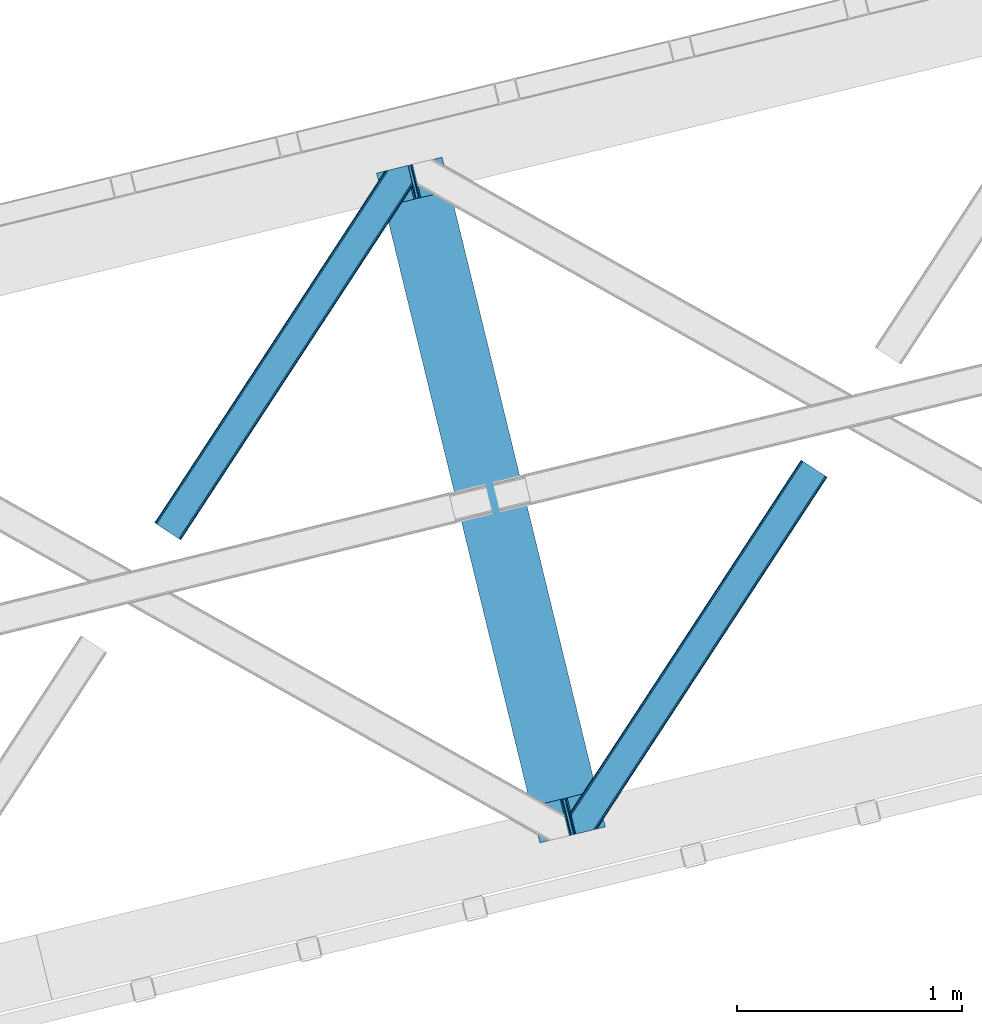
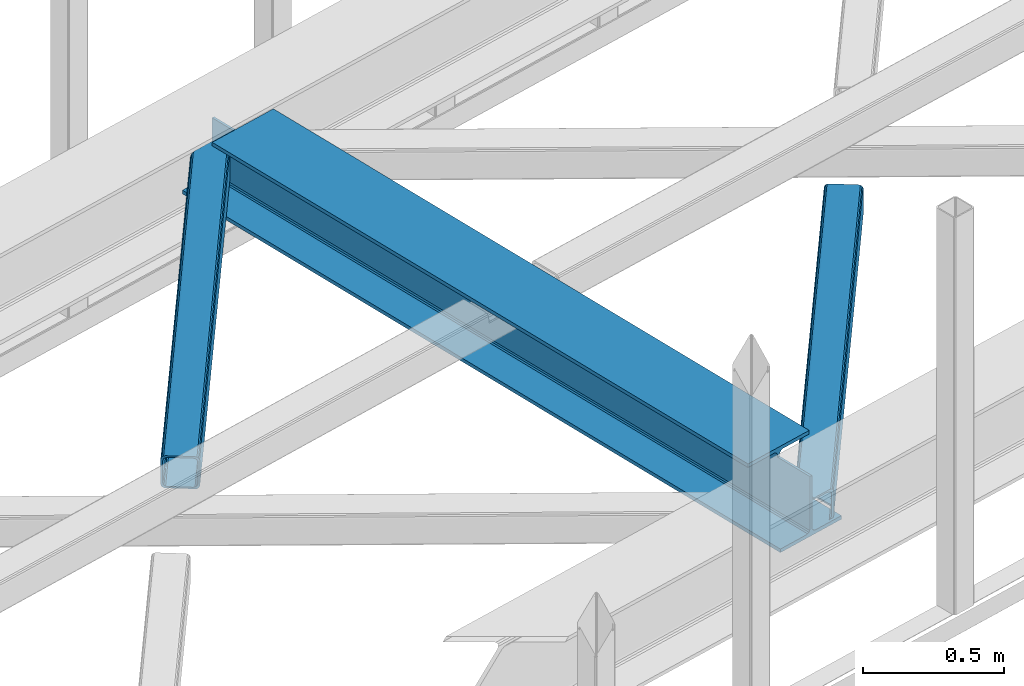
# One storey, part 31 of 66: 2 members, 1 beam.
"""IFC4 building model written with IfcOpenShell, lengths in millimetres."""

from ifc_helpers import new_model, entity, si_unit, converted_unit, derived_unit, direction, frame, origin, place, context, subcontext, project, spatial, triangles, polygons, material, type_object, element, save


model = new_model("IFC4")

# Units and contexts
model_context = context("Model", 3, precision=0.01, world=origin(), true_north=direction((6.12303176911189e-17, 1.0)))
plan_context = context("Plan", 3, precision=0.01, world=origin(), true_north=direction((6.12303176911189e-17, 1.0)))
body_context = subcontext(model_context, "Body", "Model", "MODEL_VIEW")
ifc_project = project(units=[si_unit("LENGTHUNIT", "METRE", prefix="MILLI"), si_unit("AREAUNIT", "SQUARE_METRE"), si_unit("VOLUMEUNIT", "CUBIC_METRE"), converted_unit("PLANEANGLEUNIT", "DEGREE", entity("IfcRatioMeasure", 0.0174532925199433), si_unit("PLANEANGLEUNIT", "RADIAN"), dimensions=[0, 0, 0, 0, 0, 0, 0]), si_unit("MASSUNIT", "GRAM", prefix="KILO"), derived_unit("MASSDENSITYUNIT", [(si_unit("MASSUNIT", "GRAM", prefix="KILO"), 1), (si_unit("LENGTHUNIT", "METRE"), -3)]), derived_unit("MOMENTOFINERTIAUNIT", [(si_unit("LENGTHUNIT", "METRE"), 4)]), si_unit("TIMEUNIT", "SECOND"), si_unit("FREQUENCYUNIT", "HERTZ"), si_unit("THERMODYNAMICTEMPERATUREUNIT", "DEGREE_CELSIUS"), derived_unit("THERMALTRANSMITTANCEUNIT", [(si_unit("MASSUNIT", "GRAM", prefix="KILO"), 1), (si_unit("THERMODYNAMICTEMPERATUREUNIT", "KELVIN"), -1), (si_unit("TIMEUNIT", "SECOND"), -3)]), derived_unit("VOLUMETRICFLOWRATEUNIT", [(si_unit("LENGTHUNIT", "METRE"), 3), (si_unit("TIMEUNIT", "SECOND"), -1)]), derived_unit("MASSFLOWRATEUNIT", [(si_unit("MASSUNIT", "GRAM", prefix="KILO"), 1), (si_unit("TIMEUNIT", "SECOND"), -1)]), derived_unit("ROTATIONALFREQUENCYUNIT", [(si_unit("TIMEUNIT", "SECOND"), -1)]), si_unit("ELECTRICCURRENTUNIT", "AMPERE"), si_unit("ELECTRICVOLTAGEUNIT", "VOLT"), si_unit("POWERUNIT", "WATT"), si_unit("FORCEUNIT", "NEWTON", prefix="KILO"), si_unit("ILLUMINANCEUNIT", "LUX"), si_unit("LUMINOUSFLUXUNIT", "LUMEN"), si_unit("LUMINOUSINTENSITYUNIT", "CANDELA"), derived_unit("USERDEFINED", [(si_unit("MASSUNIT", "GRAM", prefix="KILO"), -1), (si_unit("LENGTHUNIT", "METRE"), -2), (si_unit("TIMEUNIT", "SECOND"), 3), (si_unit("LUMINOUSFLUXUNIT", "LUMEN"), 1)]), derived_unit("LINEARVELOCITYUNIT", [(si_unit("LENGTHUNIT", "METRE"), 1), (si_unit("TIMEUNIT", "SECOND"), -1)]), si_unit("PRESSUREUNIT", "PASCAL"), derived_unit("USERDEFINED", [(si_unit("LENGTHUNIT", "METRE"), -2), (si_unit("MASSUNIT", "GRAM", prefix="KILO"), 1), (si_unit("TIMEUNIT", "SECOND"), -2)]), derived_unit("LINEARFORCEUNIT", [(si_unit("MASSUNIT", "GRAM", prefix="KILO"), 1), (si_unit("LENGTHUNIT", "METRE"), 1), (si_unit("TIMEUNIT", "SECOND"), -2), (si_unit("LENGTHUNIT", "METRE"), -1)]), derived_unit("PLANARFORCEUNIT", [(si_unit("MASSUNIT", "GRAM", prefix="KILO"), 1), (si_unit("LENGTHUNIT", "METRE"), 1), (si_unit("TIMEUNIT", "SECOND"), -2), (si_unit("LENGTHUNIT", "METRE"), -2)])], contexts=[model_context, plan_context])

# Site, building, storey
site_placement = place(None, origin())
site = spatial("IfcSite", under=ifc_project, at=site_placement, CompositionType="ELEMENT")
building_placement = place(site_placement, origin())
building = spatial("IfcBuilding", under=site, at=building_placement, CompositionType="ELEMENT")
storey_placement = place(building_placement, frame((0.0, 0.0, 19800.0)))
storey = spatial("IfcBuildingStorey", under=building, at=storey_placement, Name="06", CompositionType="ELEMENT", Elevation=19800.0)

# Beam
ifc_material = material(Name="Metal painted (White)")
beam_type = type_object("IfcBeamType", PredefinedType="BEAM")
beam_placement = place(storey_placement, frame((-39874.82, 8075.02, 3807.02)))
element("IfcBeam", 1, at=beam_placement, inside=storey, type_object=beam_type, material=ifc_material, ObjectType="Steel Beam", PredefinedType="BEAM", context=body_context, shape_type="Tessellation", body=[
    polygons([(1018.16648378329, 71.0478278971021, 15.5000000000008), (1018.16648378329, 71.0478278971021, 0.0), (291.465617442446, 3052.25531830421, 0.0), (291.465617442446, 3052.25531830421, 15.5000000000008), (894.779372399329, 40.9709140873291, 15.5000000000008), (168.078506058474, 3022.17840449444, 15.5000000000008), (888.087028625371, 39.3395844888243, 16.8701684147984), (161.386162284528, 3020.54707489593, 16.8701684147984), (882.413533524751, 37.9566100336508, 20.7720779386434), (155.712667183895, 3019.16410044076, 20.7720779386434), (878.622625296176, 37.0325360459151, 26.6116982174294), (151.921758955329, 3018.24002645303, 26.6116982174294), (877.291435352788, 36.7080444135018, 33.500000000001), (150.590569011932, 3017.91553482061, 33.500000000001), (140.875048430514, 3015.54727389071, 33.500000000001), (140.875048430514, 3015.54727389071, 259.000000000002), (150.590569011932, 3017.91553482061, 259.000000000002), (8.66293703438714e-12, 2981.20749040711, 0.0), (8.66293703438714e-12, 2981.20749040711, 15.4999999999965), (123.387111383972, 3011.28440421689, 15.5000000000008), (130.079455157926, 3012.91573381539, 16.8701684147984), (135.752950258551, 3014.29870827056, 20.7720779386434), (139.543858487117, 3015.22278225829, 26.6116982174294), (877.291435352783, 36.7080444135018, 259.000000000002), (867.575914771365, 34.3397834835981, 259.000000000002), (867.575914771365, 34.339783483597, 33.500000000001), (866.244724827968, 34.0152918511827, 26.6116982174294), (862.453816599397, 33.0912178634492, 20.7720779386434), (856.780321498782, 31.7082434082767, 16.8701684147984), (850.087977724828, 30.0769138097719, 15.5000000000008), (726.700866340855, 0.0, 15.4999999999965), (726.700866340855, 0.0, 0.0), (838.124523615921, 197.385937999179, 259.069791973884), (186.469722099971, 2870.72539801218, 259.000000000002), (186.69311520182, 2869.80895360721, 259.617303331124), (186.705504045446, 2869.75812937344, 266.500003008253), (837.979344808156, 197.981416001702, 266.500002998871), (837.979694928899, 197.979979696968, 260.000004007589), (828.499586345876, 194.64586594443, 259.006343171919), (828.276216326111, 195.56231748191, 259.617303331124), (828.263827482486, 195.613141715684, 266.500003008253), (176.989986719784, 2867.38985508742, 266.500002998871), (176.989636599032, 2867.39129139215, 260.000004007589), (176.844830940696, 2867.98534020594, 259.07612046749), (176.754201518561, 2868.35713708228, 259.000000000002), (839.310832678066, 198.304685446387, 273.388305639783), (843.10110926677, 199.231350618301, 279.227924098781), (848.774180214309, 200.616065081978, 283.129832400615), (855.466371895434, 202.248018612792, 284.500000377228), (978.853400583269, 232.3252716679, 284.500000138971), (978.851730776613, 232.332121736634, 299.999995328161), (687.386308679356, 161.283492472592, 299.999995890962), (687.387978486008, 161.27664240386, 284.500000701776), (810.775007173852, 191.353895458971, 284.500000463519), (817.467494069982, 192.984637925549, 283.129832461069), (823.141405718751, 194.365903570074, 279.227924137322), (826.932940505742, 195.28740721937, 273.388305663684), (175.658498849857, 2867.06658564273, 273.388305639788), (171.868222261161, 2866.13992047082, 279.227924098781), (166.195151313631, 2864.75520600714, 283.129832400619), (159.502959632506, 2863.12325247633, 284.500000377228), (36.115930944662, 2833.04599942122, 284.500000138971), (36.1176007513137, 2833.03914935249, 299.999995328161), (327.583022848575, 2904.08777861653, 299.999995890962), (327.581353041924, 2904.09462868526, 284.500000701776), (204.19432435408, 2874.01737563015, 284.500000463519), (197.501837457932, 2872.38663316357, 283.129832461065), (191.827925809181, 2871.00536751905, 279.227924137322), (188.03639102218, 2870.08386386975, 273.388305663684)], [[[1, 2, 3, 4]], [[5, 1, 4, 6]], [[7, 5, 6, 8]], [[9, 7, 8, 10]], [[11, 9, 10, 12]], [[13, 11, 12, 14]], [[15, 16, 17, 14, 12, 10, 8, 6, 4, 3, 18, 19, 20, 21, 22, 23]], [[13, 24, 25, 26, 27, 28, 29, 30, 31, 32, 2, 1, 5, 7, 9, 11]], [[2, 32, 18, 3]], [[32, 31, 19, 18]], [[31, 30, 20, 19]], [[27, 26, 15, 23]], [[28, 27, 23, 22]], [[29, 28, 22, 21]], [[30, 29, 21, 20]], [[33, 24, 13, 14, 17, 34, 35, 36, 37, 38]], [[25, 39, 40, 41, 42, 43, 44, 16, 15, 26]], [[39, 25, 24, 33]], [[45, 34, 17, 16]], [[41, 40, 38, 37, 46, 47, 48, 49, 50, 51, 52, 53, 54, 55, 56, 57]], [[42, 58, 59, 60, 61, 62, 63, 64, 65, 66, 67, 68, 69, 36, 35, 43]], [[46, 37, 36, 69]], [[47, 46, 69, 68]], [[48, 47, 68, 67]], [[49, 48, 67, 66]], [[50, 49, 66, 65]], [[51, 50, 65, 64]], [[52, 51, 64, 63]], [[53, 52, 63, 62]], [[54, 53, 62, 61]], [[55, 54, 61, 60]], [[56, 55, 60, 59]], [[57, 56, 59, 58]], [[41, 57, 58, 42]]], closed=False),
])

# Members
member_type_1 = type_object("IfcMemberType", PredefinedType="BRACE")
member_1_placement = place(storey_placement, frame((-40863.02, 9423.03, 3824.0)))
element("IfcMember", 2, at=member_1_placement, inside=storey, type_object=member_type_1, ObjectType="Steel Horizontal Brace", PredefinedType="BRACE", context=body_context, shape_type="Tessellation", body=[
    triangles([(994.776489257813, 1564.02720794678, 0.0), (1028.82557373047, 1424.34736175537, 0.0), (14.6409667968765, 67.1040435791001, 0.0), (102.486767578128, 9.58604278564417, 0.0), (1.1162109375, 75.9604797363281, 10.8039916992202), (0.0, 76.6900863647461, 17.5012573242202), (1025.02580566407, 1642.17825164795, 17.5012573242202), (4.28811035156104, 73.8821182250977, 5.12526855468968), (990.47907714844, 1585.87703704834, 9.49942016601563), (990.041894531249, 1584.44689178467, 8.74132690429906), (989.90701904297, 1583.99226837158, 8.49948120117188), (990.762780761717, 1580.48783111572, 5.12526855468968), (1027.30938720703, 1642.73519439697, 10.8691040039084), (1027.77912597657, 1642.8503036499, 9.49942016601563), (992.604528808595, 1572.9359664917, 1.33247680664135), (9.03665771484521, 70.7724243164048, 1.33247680664135), (1025.02580566407, 1642.17825164795, 122.499499511719), (0.0, 76.6900863647461, 122.499499511719), (1026.92336425781, 1642.64101409912, 129.196765136719), (1.1162109375, 75.9604797363281, 129.196765136719), (1032.31838378906, 1643.95605010986, 134.87548828125), (4.28811035156104, 73.8821182250977, 134.87548828125), (1040.39230957031, 1645.92453460693, 138.668280029298), (9.03665771484521, 70.7724243164048, 138.668280029298), (1049.91730957032, 1648.24648590088, 140.00075683594), (14.6409667968765, 67.1040435791001, 140.00075683594), (994.874157714847, 1567.85139312744, 9.49942016601563), (994.762536621092, 1567.00725860596, 9.2947814941399), (994.650915527345, 1566.15033416748, 9.08781738281323), (994.539294433598, 1565.30619964599, 8.8831787109375), (994.748583984379, 1564.14464263916, 8.49948120117188), (1047.05701904297, 1647.54769134521, 9.49942016601563), (14.892114257811, 66.9377746582031, 8.3320495605476), (20.4964233398423, 63.2693939208984, 6.99957275390625), (997.046118164064, 1554.71498565674, 6.99957275390625), (10.1435668945342, 70.0474685668942, 12.1248413085959), (1042.27591552735, 1646.3826461792, 12.1248413085959), (1036.8808959961, 1645.06761016846, 17.8035644531265), (1034.98333740234, 1644.60601043701, 24.5008300781265), (6.97166748047312, 72.1258300781246, 17.8035644531265), (5.85545654297312, 72.8560180664063, 24.5008300781265), (1026.55129394531, 1433.65958404541, 6.99957275390625), (96.6313110351548, 13.4206924438477, 6.99957275390625), (1028.71860351563, 1424.77640533447, 8.41343994140698), (1032.83463134766, 1407.88673858643, 5.12526855468968), (1033.6903930664, 1404.38230133057, 8.49948120117188), (1030.99288330078, 1415.43860321045, 1.33247680664135), (1034.98333740234, 1644.60601043701, 115.499926757813), (5.85545654297312, 72.8560180664063, 115.499926757813), (1050.3498413086, 1648.35113067627, 131.668707275392), (1059.87484130859, 1650.67308197021, 133.001184082033), (20.4964233398423, 63.2693939208984, 133.001184082033), (14.892114257811, 66.9377746582031, 131.668707275392), (1042.27591552735, 1646.3826461792, 127.873590087893), (10.1435668945342, 70.0474685668942, 127.873590087893), (1036.8808959961, 1645.06761016846, 122.197192382813), (6.97166748047312, 72.1258300781246, 122.197192382813), (1128.10788574219, 1667.30578765869, 140.00075683594), (1128.10788574219, 1667.30578765869, 133.001184082033), (1144.33015136719, 1600.75868682861, 140.00075683594), (102.486767578128, 9.58604278564417, 140.00075683594), (1142.06052246094, 1610.06974639893, 133.001184082033), (96.6313110351548, 13.4206924438477, 133.001184082033), (1146.50211181641, 1591.84876556396, 138.668280029298), (108.091076660159, 5.91766204833948, 138.668280029298), (1148.34385986329, 1584.29690093994, 134.87548828125), (112.839624023436, 2.80738677978479, 134.87548828125), (1149.57169189453, 1579.25069732666, 129.196765136719), (116.011523437504, 0.729606628417969, 129.196765136719), (1150.00422363282, 1577.47871246338, 122.499499511719), (117.127734375004, 0.0, 122.499499511719), (1150.00422363282, 1577.47871246338, 17.5012573242202), (117.127734375004, 0.0, 17.5012573242202), (106.98416748047, 6.64203643798828, 127.873590087893), (110.156066894531, 4.56367492675781, 122.197192382813), (111.272277832031, 3.83464965820167, 115.499926757813), (102.230969238284, 9.75173034667932, 131.668707275392), (116.011523437504, 0.729606628417969, 10.8039916992202), (106.98416748047, 6.64203643798828, 12.1248413085959), (112.839624023436, 2.80738677978479, 5.12526855468968), (111.272277832031, 3.83464965820167, 24.5008300781265), (110.156066894531, 4.56367492675781, 17.8035644531265), (108.091076660159, 5.91766204833948, 1.33247680664135), (102.230969238284, 9.75173034667932, 8.3320495605476), (1147.30206298828, 1588.56175689697, 122.197192382813), (1147.73459472656, 1586.78977203369, 115.499926757813), (1146.07423095703, 1593.60912322998, 127.873590087893), (1144.23248291016, 1601.160987854, 131.668707275392), (1147.73459472656, 1586.78977203369, 24.5008300781265), (1147.21369628907, 1588.92452545166, 17.8686767578147), (1149.994921875, 1577.51591949463, 16.5013183593765), (1147.10672607422, 1589.36519622803, 16.5013183593765), (1145.27427978516, 1573.10804901123, 10.8714294433594), (1034.62056884765, 1404.78809051514, 9.49942016601563), (1144.12551269531, 1572.03369598389, 9.49942016601563), (1142.79071044922, 1588.5978012085, 12.1248413085959), (1030.22548828125, 1422.81373443603, 9.49942016601563), (1029.19764404297, 1423.67182159424, 8.80643920898365), (1139.7304321289, 1590.06050262451, 9.49942016601563)], [[1, 2, 3], [4, 3, 2], [5, 6, 7], [8, 9, 10], [11, 12, 8], [5, 13, 9], [9, 8, 5], [13, 14, 9], [15, 1, 16], [3, 16, 1], [12, 15, 8], [16, 8, 15], [7, 13, 5], [17, 7, 6], [6, 18, 17], [19, 17, 20], [18, 20, 17], [21, 19, 22], [20, 22, 19], [23, 21, 24], [22, 24, 21], [25, 23, 26], [24, 26, 23], [27, 28, 9], [28, 29, 10], [29, 30, 10], [30, 31, 11], [14, 32, 27], [27, 9, 14], [33, 34, 35], [36, 33, 31], [31, 30, 36], [28, 36, 29], [28, 27, 36], [36, 30, 29], [32, 37, 27], [36, 27, 37], [35, 31, 33], [38, 39, 40], [41, 40, 39], [37, 38, 36], [40, 36, 38], [42, 35, 34], [34, 43, 42], [1, 35, 42], [31, 12, 11], [1, 31, 35], [31, 15, 12], [31, 1, 15], [2, 1, 42], [44, 2, 42], [45, 44, 46], [44, 47, 2], [44, 45, 47], [39, 48, 49], [49, 41, 39], [50, 51, 52], [52, 53, 50], [54, 50, 53], [53, 55, 54], [56, 54, 55], [55, 57, 56], [48, 56, 57], [57, 49, 48], [56, 17, 19], [50, 23, 25], [58, 51, 25], [51, 58, 59], [51, 50, 25], [54, 23, 50], [54, 56, 21], [21, 23, 54], [19, 21, 56], [39, 7, 17], [37, 14, 38], [56, 48, 17], [37, 32, 14], [39, 38, 7], [48, 39, 17], [13, 7, 38], [38, 14, 13], [60, 25, 61], [25, 60, 58], [26, 61, 25], [51, 62, 63], [51, 59, 62], [63, 52, 51], [64, 60, 61], [61, 65, 64], [66, 64, 65], [65, 67, 66], [68, 66, 67], [67, 69, 68], [70, 68, 69], [69, 71, 70], [72, 70, 71], [71, 73, 72], [69, 74, 75], [76, 73, 71], [69, 75, 71], [69, 67, 74], [75, 76, 71], [74, 67, 65], [63, 61, 26], [61, 77, 65], [77, 61, 63], [77, 74, 65], [78, 79, 80], [81, 73, 76], [73, 82, 78], [82, 73, 81], [78, 82, 79], [4, 43, 3], [83, 80, 79], [79, 84, 83], [84, 43, 4], [4, 83, 84], [55, 24, 22], [26, 52, 63], [26, 53, 52], [53, 26, 24], [55, 53, 24], [49, 18, 6], [20, 57, 55], [22, 20, 55], [57, 20, 18], [49, 57, 18], [16, 36, 8], [3, 43, 34], [34, 33, 3], [33, 36, 16], [16, 3, 33], [5, 8, 36], [6, 41, 49], [40, 6, 5], [6, 40, 41], [40, 5, 36], [85, 86, 75], [76, 75, 86], [87, 85, 74], [75, 74, 85], [88, 87, 77], [74, 77, 87], [62, 88, 63], [77, 63, 88], [86, 89, 81], [81, 76, 86], [90, 91, 92], [70, 72, 89], [72, 90, 89], [89, 86, 70], [72, 91, 90], [85, 70, 86], [68, 70, 85], [66, 85, 87], [85, 66, 68], [87, 64, 66], [88, 64, 87], [88, 62, 60], [88, 60, 64], [62, 58, 60], [62, 59, 58], [73, 78, 93], [93, 72, 73], [94, 93, 78], [94, 95, 93], [80, 45, 46], [46, 78, 80], [46, 94, 78], [47, 45, 83], [80, 83, 45], [2, 47, 4], [83, 4, 47], [93, 91, 72], [82, 81, 89], [82, 92, 96], [82, 90, 92], [84, 97, 98], [79, 96, 97], [97, 84, 79], [96, 99, 97], [43, 84, 44], [44, 42, 43], [96, 79, 82], [89, 90, 82], [96, 91, 93], [96, 92, 91], [96, 95, 99], [93, 95, 96], [99, 95, 97], [94, 97, 95]]),
])
member_type_2 = type_object("IfcMemberType", PredefinedType="BRACE")
member_2_placement = place(storey_placement, frame((-39011.7, 8114.1, 3824.0)))
element("IfcMember", 3, at=member_2_placement, inside=storey, type_object=member_type_2, ObjectType="Steel Horizontal Brace", PredefinedType="BRACE", context=body_context, shape_type="Tessellation", body=[
    triangles([(109.770043945311, 259.950411987305, 7.52047119140843), (115.030187988283, 238.366264343263, 7.77626953125218), (114.216284179689, 239.946981811524, 8.3320495605476), (108.809637451173, 259.66263885498, 8.52041015625218), (113.637249755855, 239.860359191895, 8.52041015625218), (112.209429931638, 237.677934265136, 8.52041015625218), (91.0363037109346, 232.516621398926, 8.52041015625218), (109.537499999999, 237.026811218261, 9.49942016601563), (90.2619323730469, 232.328260803223, 9.49942016601563), (5.02062377929542, 77.405158996582, 9.49942016601563), (0.62786865234375, 95.4313842773436, 9.49942016601563), (1046.62448730469, 1651.75382995606, 6.99957275390625), (1041.02017822266, 1655.42221069336, 8.3320495605476), (116.702178955078, 231.514938354493, 6.99957275390625), (1036.27395629883, 1658.53248596192, 12.1248413085959), (3.93231811523583, 81.8758163452158, 12.1248413085959), (1033.09740600586, 1660.61026611328, 17.8035644531265), (2.70216064452688, 86.922019958497, 17.8035644531265), (1031.98352050781, 1661.34045410156, 24.5008300781265), (2.26962890625146, 88.6940048217775, 24.5008300781265), (1122.75704956055, 1601.905128479, 6.99957275390625), (146.20968017578, 110.459536743164, 6.99957275390625), (1031.98352050781, 1661.34045410156, 115.499926757813), (2.26962890625146, 88.6940048217775, 115.499926757813), (1033.09740600586, 1660.61026611328, 122.197192382813), (2.70216064452688, 86.922019958497, 122.197192382813), (1036.27395629883, 1658.53248596192, 127.873590087893), (3.93231811523583, 81.8758163452158, 127.873590087893), (1041.02017822266, 1655.42221069336, 131.668707275392), (5.77174072265188, 74.3233703613287, 131.668707275392), (1046.62448730469, 1651.75382995606, 133.001184082033), (7.94370117187646, 65.4146118164063, 133.001184082033), (1027.24194946289, 1664.44491577149, 10.8039916992202), (0.518572998043965, 95.8720550537118, 10.8691040039084), (0.0, 98.0062271118159, 17.5012573242202), (1035.16472167968, 1659.25686035156, 1.33247680664135), (112.260589599609, 249.735919189453, 1.33247680664135), (110.544415283199, 256.772117614747, 5.59500732422021), (109.077062988283, 259.839953613281, 8.32042236328198), (1030.41384887695, 1662.36713562012, 5.12526855468968), (1040.76670532226, 1655.58847961426, 0.0), (114.430224609372, 240.827160644531, 0.0), (1026.12806396484, 1665.17510375977, 17.5012573242202), (1128.61250610351, 1598.0704788208, 0.0), (148.479309082031, 101.147895812989, 0.0), (150.651269531249, 92.2391372680659, 1.33247680664135), (148.509539794919, 101.029879760742, 8.49948120117188), (152.493017578126, 84.6866912841806, 5.12526855468968), (153.346453857419, 81.1828353881838, 8.49948120117188), (1026.12806396484, 1665.17510375977, 122.499499511719), (0.0, 98.0062271118159, 122.499499511719), (1040.76670532226, 1655.58847961426, 140.00075683594), (1035.16472167968, 1659.25686035156, 138.668280029298), (3.50211181640771, 83.6350112915034, 138.668280029298), (5.674072265625, 74.7262527465818, 140.00075683594), (1030.41384887695, 1662.36713562012, 134.87548828125), (1.66036376952979, 91.1874572753904, 134.87548828125), (1027.24194946289, 1664.44491577149, 129.196765136719), (0.430206298828125, 96.2342422485353, 129.196765136719), (23.8892395019502, 0.0, 140.00075683594), (23.8892395019502, 0.0, 133.001184082033), (1128.61250610351, 1598.0704788208, 140.00075683594), (93.3361633300738, 16.9286178588873, 140.00075683594), (1122.75704956055, 1601.905128479, 133.001184082033), (83.3809570312515, 14.5020217895508, 133.001184082033), (1143.25347290039, 1588.48443603516, 122.499499511719), (1142.13958740234, 1589.21404266358, 129.196765136719), (118.225341796875, 22.9956893920898, 122.499499511719), (116.332434082033, 22.5340896606449, 129.196765136719), (1138.96536254883, 1591.29182281494, 134.87548828125), (110.935089111328, 21.2184722900392, 134.87548828125), (1134.21681518554, 1594.40267944336, 138.668280029298), (102.861163330075, 19.2499877929686, 138.668280029298), (1143.25347290039, 1588.48443603516, 17.5012573242202), (118.225341796875, 22.9956893920898, 17.5012573242202), (1142.13958740234, 1589.21404266358, 10.8039916992202), (1133.10990600586, 1595.12647247315, 12.1248413085959), (1136.28180541992, 1593.04811096192, 17.8035644531265), (1137.39801635742, 1592.31908569336, 24.5008300781265), (1138.96536254883, 1591.29182281494, 5.12526855468968), (1134.21681518554, 1594.40267944336, 1.33247680664135), (1128.35903320312, 1598.2367477417, 8.3320495605476), (1133.10990600586, 1595.12647247315, 127.873590087893), (1137.39801635742, 1592.31908569336, 115.499926757813), (1136.28180541992, 1593.04811096192, 122.197192382813), (1128.35903320312, 1598.2367477417, 131.668707275392), (92.9059570312456, 16.8239730834966, 131.668707275392), (100.979882812499, 18.7918762207037, 127.873590087893), (106.374902343749, 20.1069122314457, 122.197192382813), (108.270135498045, 20.5685119628906, 115.499926757813), (108.270135498045, 20.5685119628906, 24.5008300781265), (100.979882812499, 18.7918762207037, 12.1248413085959), (115.474346923824, 22.3248001098636, 9.49942016601563), (106.374902343749, 20.1069122314457, 17.8035644531265), (96.2011047363267, 17.6268310546875, 9.49942016601563), (115.944085693358, 22.4393280029299, 10.8691040039084), (153.060424804688, 80.2398696899409, 8.99945068359375), (152.776721191403, 79.2974853515634, 9.49942016601563), (148.711853027344, 99.8683227539068, 8.8831787109375), (148.602557373044, 99.023606872558, 9.08781738281323), (148.493261718751, 98.1678451538091, 9.2947814941399), (148.381640624997, 97.3231292724604, 9.49942016601563)], [[1, 2, 3], [4, 5, 6], [6, 7, 4], [7, 6, 8], [8, 9, 7], [9, 8, 10], [10, 11, 9], [12, 13, 3], [3, 2, 12], [2, 14, 12], [15, 16, 8], [8, 13, 15], [8, 5, 13], [16, 10, 8], [8, 6, 5], [15, 17, 18], [18, 16, 15], [17, 19, 20], [20, 18, 17], [21, 12, 14], [14, 22, 21], [19, 23, 24], [24, 20, 19], [23, 25, 24], [26, 24, 25], [25, 27, 26], [28, 26, 27], [27, 29, 28], [30, 28, 29], [29, 31, 30], [32, 30, 31], [33, 34, 35], [36, 37, 38], [33, 4, 9], [33, 1, 39], [9, 34, 33], [9, 11, 34], [4, 7, 9], [40, 38, 1], [1, 33, 40], [38, 40, 36], [36, 41, 37], [42, 37, 41], [35, 43, 33], [41, 44, 42], [45, 42, 44], [14, 42, 22], [37, 2, 38], [2, 37, 42], [38, 2, 1], [42, 14, 2], [22, 42, 45], [46, 47, 45], [47, 46, 48], [45, 47, 22], [48, 49, 47], [50, 43, 35], [35, 51, 50], [52, 53, 54], [54, 55, 52], [53, 56, 57], [57, 54, 53], [56, 58, 59], [59, 57, 56], [58, 50, 51], [51, 59, 58], [28, 57, 26], [30, 32, 55], [32, 60, 55], [32, 61, 60], [54, 30, 55], [28, 54, 57], [16, 11, 10], [28, 30, 54], [51, 35, 20], [24, 26, 51], [24, 51, 20], [57, 59, 26], [26, 59, 51], [35, 18, 20], [18, 11, 16], [11, 18, 34], [35, 34, 18], [62, 55, 63], [62, 52, 55], [55, 60, 63], [64, 32, 31], [32, 64, 65], [61, 32, 65], [66, 67, 68], [69, 68, 67], [67, 70, 69], [71, 69, 70], [70, 72, 71], [73, 71, 72], [72, 62, 73], [63, 73, 62], [74, 66, 68], [68, 75, 74], [76, 77, 78], [79, 66, 74], [76, 78, 74], [76, 80, 77], [78, 79, 74], [77, 80, 81], [21, 44, 41], [44, 82, 81], [82, 44, 21], [82, 77, 81], [67, 83, 70], [84, 66, 79], [66, 85, 67], [85, 66, 84], [67, 85, 83], [62, 64, 52], [72, 70, 83], [83, 86, 72], [86, 64, 62], [62, 72, 86], [15, 36, 40], [41, 12, 21], [41, 13, 12], [13, 41, 36], [15, 13, 36], [19, 43, 50], [33, 17, 15], [40, 33, 15], [17, 33, 43], [19, 17, 43], [53, 27, 56], [52, 64, 31], [31, 29, 52], [29, 27, 53], [53, 52, 29], [58, 56, 27], [50, 23, 19], [25, 50, 58], [50, 25, 23], [25, 58, 27], [64, 86, 87], [87, 65, 64], [86, 83, 88], [88, 87, 86], [83, 85, 89], [89, 88, 83], [85, 84, 90], [90, 89, 85], [84, 79, 91], [91, 90, 84], [89, 68, 69], [87, 73, 63], [60, 65, 63], [65, 60, 61], [65, 87, 63], [88, 73, 87], [88, 89, 71], [71, 73, 88], [69, 71, 89], [91, 75, 68], [92, 93, 94], [89, 90, 68], [92, 95, 93], [91, 94, 75], [90, 91, 68], [96, 75, 94], [94, 93, 96], [76, 74, 75], [49, 80, 97], [98, 97, 80], [49, 48, 80], [76, 96, 98], [98, 80, 76], [96, 93, 98], [44, 81, 45], [46, 45, 81], [81, 80, 46], [48, 46, 80], [75, 96, 76], [82, 21, 22], [77, 82, 47], [47, 99, 77], [77, 100, 101], [100, 77, 99], [101, 102, 77], [77, 102, 92], [95, 92, 102], [22, 47, 82], [79, 78, 91], [94, 91, 78], [78, 77, 94], [92, 94, 77], [102, 101, 98], [101, 100, 97], [100, 99, 49], [99, 47, 49], [102, 98, 93], [93, 95, 102]]),
])

save(model, "model.ifc")
